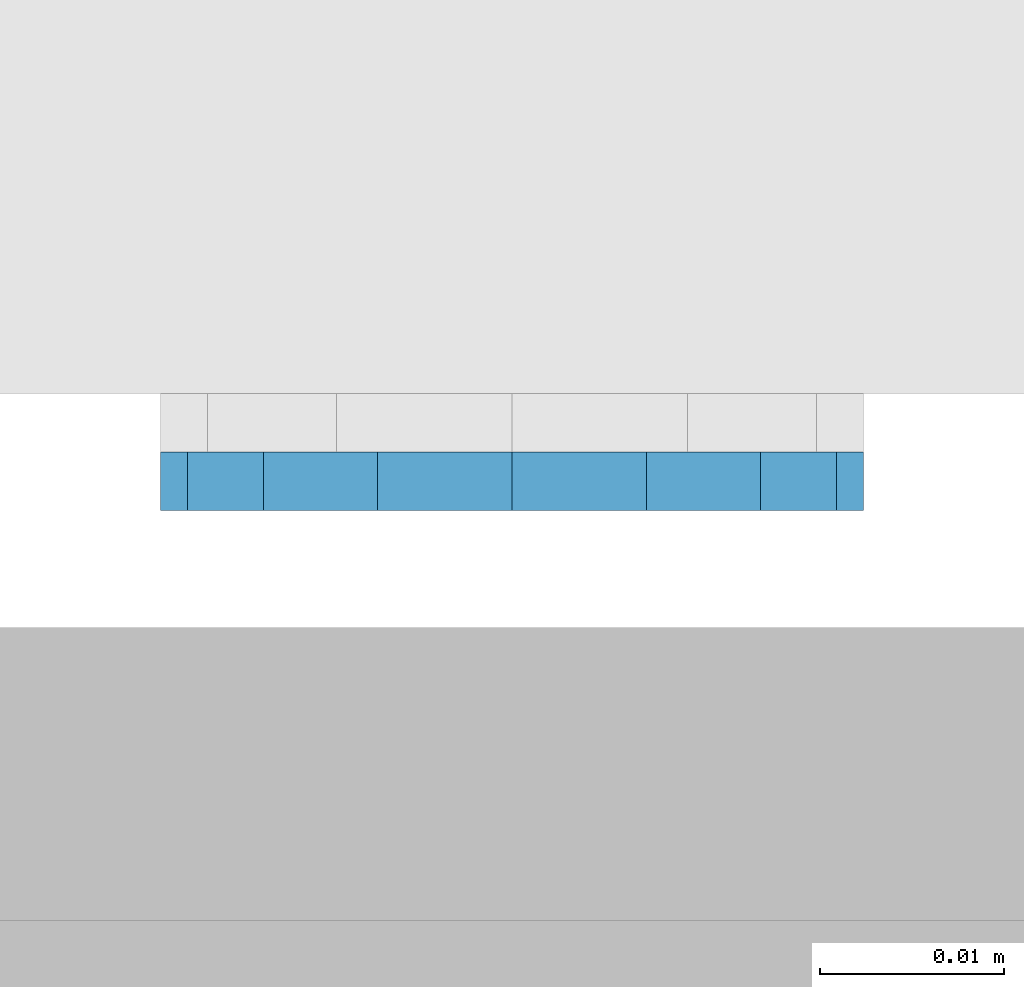
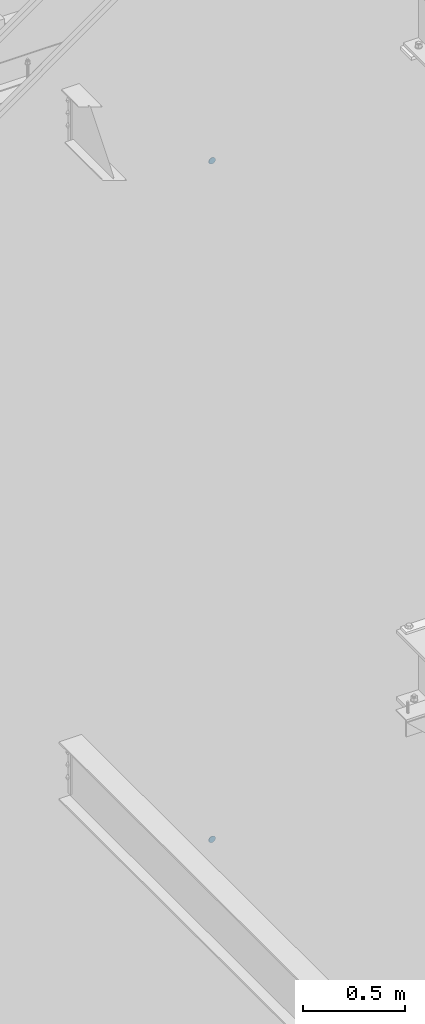
# One storey, part 1128 of 1179: 2 plates, 2 elements without a shape of their own.
"""IFC2X3 building model written with IfcOpenShell, lengths in millimetres."""

from ifc_helpers import new_model, si_unit, frame, origin_with_axes, place, context, subcontext, project, spatial, faceted_brep, material, type_object, element, aggregate, save


model = new_model("IFC2X3")

# Units and contexts
model_context = context("Model", 3, precision=1e-05, world=origin_with_axes())
body_context = subcontext(model_context, "Body", "Model", "MODEL_VIEW")
ifc_project = project(units=[si_unit("LENGTHUNIT", "METRE", prefix="MILLI"), si_unit("AREAUNIT", "SQUARE_METRE"), si_unit("VOLUMEUNIT", "CUBIC_METRE"), si_unit("MASSUNIT", "GRAM", prefix="KILO"), si_unit("TIMEUNIT", "SECOND"), si_unit("PLANEANGLEUNIT", "RADIAN"), si_unit("SOLIDANGLEUNIT", "STERADIAN"), si_unit("THERMODYNAMICTEMPERATUREUNIT", "DEGREE_CELSIUS"), si_unit("LUMINOUSINTENSITYUNIT", "LUMEN")], contexts=[model_context])

# Site, building, storey
site_placement = place(None, origin_with_axes())
site = spatial("IfcSite", under=ifc_project, at=site_placement, CompositionType="ELEMENT")
building_placement = place(site_placement, origin_with_axes())
building = spatial("IfcBuilding", under=site, at=building_placement, Name="Undefined", CompositionType="ELEMENT")
storey_placement = place(building_placement, origin_with_axes())
storey = spatial("IfcBuildingStorey", under=building, at=storey_placement, Name="Undefined", CompositionType="ELEMENT", Elevation=0.0)

# Assembly, plate
assembly_1_placement = place(storey_placement, origin_with_axes())
assembly_1 = element("IfcElementAssembly", 1, at=assembly_1_placement, inside=storey, Name="HANDRAIL", AssemblyPlace="NOTDEFINED", PredefinedType="RIGID_FRAME")
ifc_material = material(Name="STEEL/A36")
plate_type = type_object("IfcPlateType", PredefinedType="NOTDEFINED")
plate_1_placement = place(assembly_1_placement, frame((23279.0999994053, 38101.5875, 7124.70000099112), z_axis=(-1.0, 0.0, 0.0), x_axis=(0.0, 0.0, -1.0)))
plate_1 = element("IfcPlate", 2, at=plate_1_placement, type_object=plate_type, material=ifc_material, Name="PLATE", context=body_context, shape_type="Brep", body=[
    faceted_brep([(0.0, -1.58750000000146, 19.0499992370605), (1.4500948475843, -1.58750000000146, 26.3401198575302), (1.4500948475843, 1.58750000000146, 26.3401198575302), (0.0, 1.58750000000146, 19.0499992370605), (5.57961559493651, -1.58750000000146, 32.5203844050629), (5.57961559493651, 1.58750000000146, 32.5203844050629), (11.7598801424701, -1.58750000000146, 36.6499051524152), (11.7598801424701, 1.58750000000146, 36.6499051524152), (19.0500007629398, -1.58750000000146, 38.0999999999985), (19.0500007629398, 1.58750000000146, 38.0999999999985), (26.3401198575302, -1.58750000000146, 36.6499051524152), (26.3401198575302, 1.58750000000146, 36.6499051524152), (32.5203844050639, -1.58750000000146, 32.5203844050629), (32.5203844050639, 1.58750000000146, 32.5203844050629), (36.6499051524161, -1.58750000000146, 26.3401198575302), (36.6499051524161, 1.58750000000146, 26.3401198575302), (38.1000000000004, -1.58750000000146, 19.0499992370605), (38.1000000000004, 1.58750000000146, 19.0499992370605), (36.6499051524161, -1.58750000000146, 11.7598801424683), (36.6499051524161, 1.58750000000146, 11.7598801424683), (32.5203844050639, -1.58750000000146, 5.5796155949356), (32.5203844050639, 1.58750000000146, 5.5796155949356), (26.3401198575302, -1.58750000000146, 1.45009484758339), (26.3401198575302, 1.58750000000146, 1.45009484758339), (19.0499992370605, -1.58750000000146, 0.0), (19.0499992370605, 1.58750000000146, 0.0), (11.7598801424701, -1.58750000000146, 1.45009484758339), (11.7598801424701, 1.58750000000146, 1.45009484758339), (5.57961559493651, -1.58750000000146, 5.5796155949356), (5.57961559493651, 1.58750000000146, 5.5796155949356), (1.4500948475843, -1.58750000000146, 11.7598801424683), (1.4500948475843, 1.58750000000146, 11.7598801424683)], [[[0, 1, 2, 3]], [[1, 4, 5, 2]], [[4, 6, 7, 5]], [[6, 8, 9, 7]], [[8, 10, 11, 9]], [[10, 12, 13, 11]], [[12, 14, 15, 13]], [[14, 16, 17, 15]], [[16, 18, 19, 17]], [[18, 20, 21, 19]], [[20, 22, 23, 21]], [[22, 24, 25, 23]], [[24, 26, 27, 25]], [[26, 28, 29, 27]], [[28, 30, 31, 29]], [[30, 0, 3, 31]], [[5, 7, 9, 11, 13, 15, 17, 19, 21, 23, 25, 27, 29, 31, 3, 2]], [[30, 28, 26, 24, 22, 20, 18, 16, 14, 12, 10, 8, 6, 4, 1, 0]]]),
])
aggregate(assembly_1, [plate_1])

assembly_2_placement = place(storey_placement, origin_with_axes())
assembly_2 = element("IfcElementAssembly", 3, at=assembly_2_placement, inside=storey, Name="HANDRAIL", AssemblyPlace="NOTDEFINED", PredefinedType="RIGID_FRAME")
plate_2_placement = place(assembly_2_placement, frame((23279.0999997752, 38101.5874999694, 3051.17500000132), z_axis=(-1.0, 0.0, 0.0), x_axis=(0.0, 0.0, -1.0)))
plate_2 = element("IfcPlate", 4, at=plate_2_placement, type_object=plate_type, material=ifc_material, Name="PLATE", context=body_context, shape_type="Brep", body=[
    faceted_brep([(0.0, -1.58750000000146, 19.0499992370605), (1.4500948475843, -1.58750000000146, 26.3401198575302), (1.4500948475843, 1.58750000000146, 26.3401198575302), (0.0, 1.58750000000146, 19.0499992370605), (5.57961559493651, -1.58750000000146, 32.5203844050629), (5.57961559493651, 1.58750000000146, 32.5203844050629), (11.7598801424701, -1.58750000000146, 36.6499051524152), (11.7598801424701, 1.58750000000146, 36.6499051524152), (19.0500007629398, -1.58750000000146, 38.0999999999985), (19.0500007629398, 1.58750000000146, 38.0999999999985), (26.3401198575302, -1.58750000000146, 36.6499051524152), (26.3401198575302, 1.58750000000146, 36.6499051524152), (32.5203844050639, -1.58750000000146, 32.5203844050629), (32.5203844050639, 1.58750000000146, 32.5203844050629), (36.6499051524161, -1.58750000000146, 26.3401198575302), (36.6499051524161, 1.58750000000146, 26.3401198575302), (38.1000000000004, -1.58750000000146, 19.0499992370605), (38.1000000000004, 1.58750000000146, 19.0499992370605), (36.6499051524161, -1.58750000000146, 11.7598801424683), (36.6499051524161, 1.58750000000146, 11.7598801424683), (32.5203844050639, -1.58750000000146, 5.5796155949356), (32.5203844050639, 1.58750000000146, 5.5796155949356), (26.3401198575302, -1.58750000000146, 1.45009484758339), (26.3401198575302, 1.58750000000146, 1.45009484758339), (19.0499992370605, -1.58750000000146, 0.0), (19.0499992370605, 1.58750000000146, 0.0), (11.7598801424701, -1.58750000000146, 1.45009484758339), (11.7598801424701, 1.58750000000146, 1.45009484758339), (5.57961559493651, -1.58750000000146, 5.5796155949356), (5.57961559493651, 1.58750000000146, 5.5796155949356), (1.4500948475843, -1.58750000000146, 11.7598801424683), (1.4500948475843, 1.58750000000146, 11.7598801424683)], [[[0, 1, 2, 3]], [[1, 4, 5, 2]], [[4, 6, 7, 5]], [[6, 8, 9, 7]], [[8, 10, 11, 9]], [[10, 12, 13, 11]], [[12, 14, 15, 13]], [[14, 16, 17, 15]], [[16, 18, 19, 17]], [[18, 20, 21, 19]], [[20, 22, 23, 21]], [[22, 24, 25, 23]], [[24, 26, 27, 25]], [[26, 28, 29, 27]], [[28, 30, 31, 29]], [[30, 0, 3, 31]], [[5, 7, 9, 11, 13, 15, 17, 19, 21, 23, 25, 27, 29, 31, 3, 2]], [[30, 28, 26, 24, 22, 20, 18, 16, 14, 12, 10, 8, 6, 4, 1, 0]]]),
])
aggregate(assembly_2, [plate_2])

save(model, "model.ifc")
